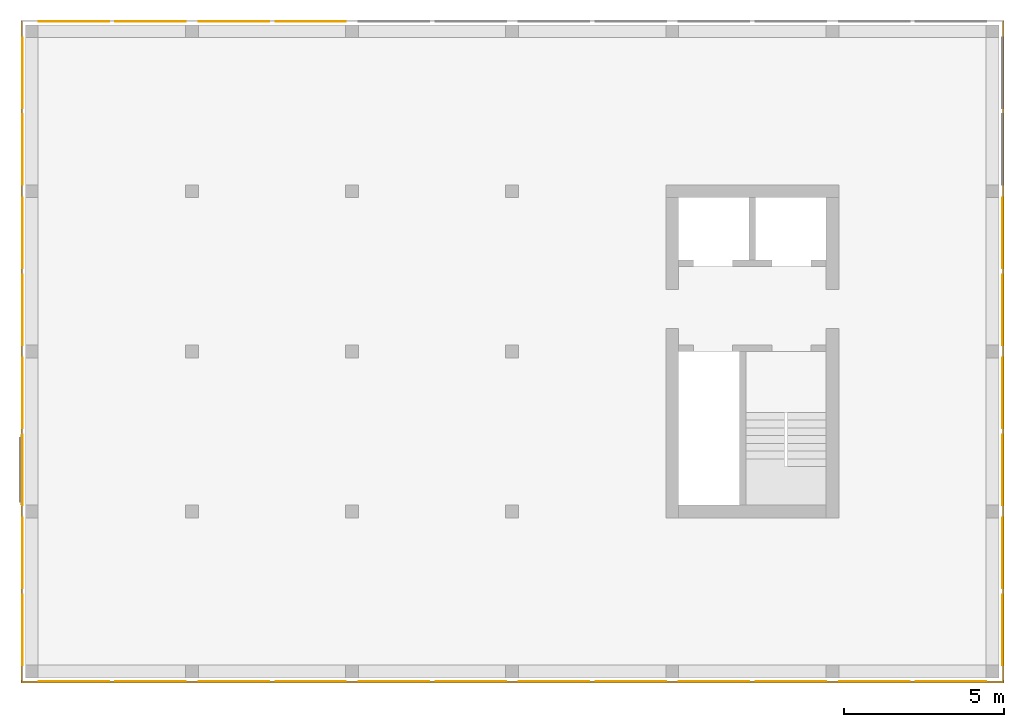
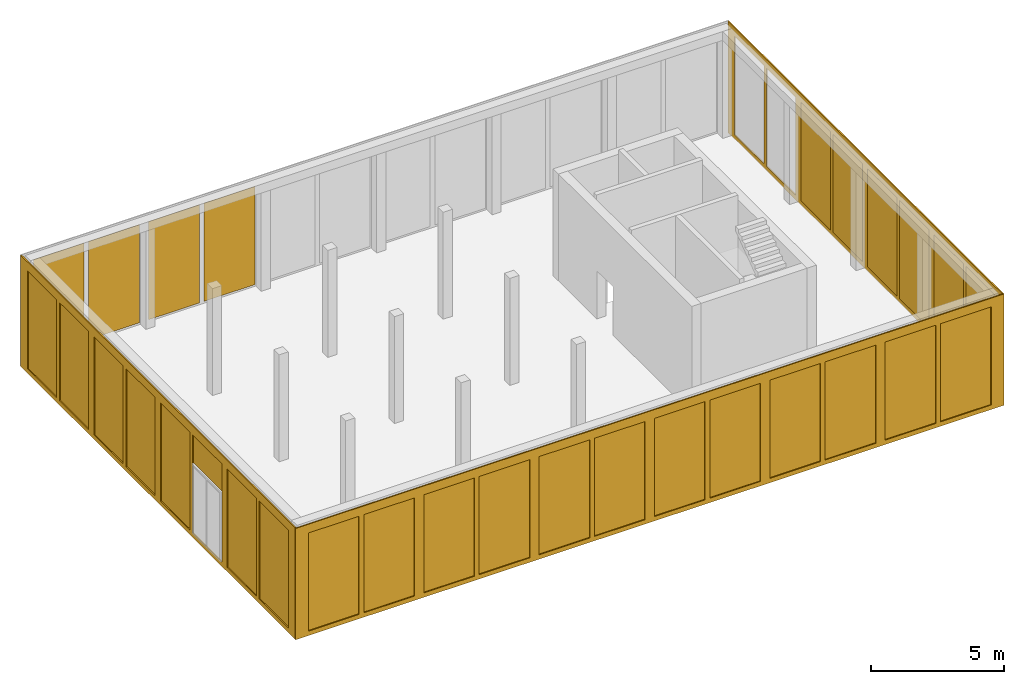
# One storey, part 3 of 5: 33 curtain walls.
"""IFC2X3 building model written with IfcOpenShell, lengths in metres."""

from ifc_helpers import new_model, entity, si_unit, converted_unit, frame, origin, place, context, subcontext, project, spatial, faceted_brep, material, element, save


model = new_model("IFC2X3")

# Units and contexts
model_context = context("Model", 3, precision=1e-05, world=origin())
body_context = subcontext(model_context, "Body", "Model", "MODEL_VIEW")
ifc_project = project(units=[si_unit("LENGTHUNIT", "METRE"), si_unit("AREAUNIT", "SQUARE_METRE"), si_unit("VOLUMEUNIT", "CUBIC_METRE"), si_unit("MASSUNIT", "GRAM", prefix="KILO"), converted_unit("PLANEANGLEUNIT", "DEGREE", entity("IfcPlaneAngleMeasure", 0.0174532925199433), si_unit("PLANEANGLEUNIT", "RADIAN"), dimensions=[0, 0, 0, 0, 0, 0, 0])], contexts=[model_context])

# Site, building, storey
site_placement = place(None, origin())
site = spatial("IfcSite", under=ifc_project, at=site_placement, CompositionType="ELEMENT")
building_placement = place(site_placement, origin())
building = spatial("IfcBuilding", under=site, at=building_placement, CompositionType="ELEMENT")
storey_placement = place(building_placement, frame((0.0, 0.0, -0.2)))
storey = spatial("IfcBuildingStorey", under=building, at=storey_placement, Name="Erdgeschoss", CompositionType="ELEMENT", Elevation=-0.2)

# Curtain walls
ifc_material_1 = material(Name="ALU")
curtain_wall_1_placement = place(storey_placement, frame((-0.139330706017223, -0.15, -0.2)))
element("IfcCurtainWall", 1, at=curtain_wall_1_placement, inside=storey, material=ifc_material_1, Name="Profil SN", context=body_context, shape_type="Brep", body=[
    faceted_brep([(0.0, 0.0500000000000001, 5.1), (30.7, 0.0500000000000001, 5.1), (30.7, 5.6843418860808e-17, 5.1), (0.0, 5.6843418860808e-17, 5.1), (30.7, 0.0500000000000001, 0.0), (30.7, 5.6843418860808e-17, 0.0), (30.15, 5.6843418860808e-17, 0.2), (30.15, 0.0500000000000001, 0.2), (30.15, 0.05, 4.7), (30.15, 0.0, 4.7), (27.95, 0.0500000000000001, 0.2), (27.95, 5.6843418860808e-17, 0.2), (27.95, 0.0, 4.7), (27.95, 0.05, 4.7), (27.75, 5.6843418860808e-17, 0.2), (27.75, 0.0500000000000001, 0.2), (27.75, 0.05, 4.7), (27.75, 0.0, 4.7), (25.55, 5.6843418860808e-17, 0.2), (25.55, 0.0500000000000001, 0.2), (25.55, 0.0, 4.7), (25.55, 0.05, 4.7), (25.15, 5.6843418860808e-17, 0.2), (25.15, 0.0500000000000001, 0.2), (25.15, 0.05, 4.7), (25.15, 0.0, 4.7), (22.95, 5.6843418860808e-17, 0.2), (22.95, 0.0500000000000001, 0.2), (22.95, 0.0, 4.7), (22.95, 0.05, 4.7), (22.75, 5.6843418860808e-17, 0.2), (22.75, 0.0500000000000001, 0.2), (22.75, 0.05, 4.7), (22.75, 0.0, 4.7), (20.55, 0.0500000000000001, 0.2), (20.55, 5.6843418860808e-17, 0.2), (20.55, 0.0, 4.7), (20.55, 0.05, 4.7), (20.15, 5.6843418860808e-17, 0.2), (20.15, 0.0500000000000001, 0.2), (20.15, 0.05, 4.7), (20.15, 0.0, 4.7), (17.95, 0.0500000000000001, 0.2), (17.95, 5.6843418860808e-17, 0.2), (17.75, 5.6843418860808e-17, 0.2), (15.55, 5.6843418860808e-17, 0.2), (15.55, 0.0500000000000001, 0.2), (17.75, 0.0500000000000001, 0.2), (12.95, 0.0500000000000001, 0.2), (15.15, 0.0500000000000001, 0.2), (15.15, 5.6843418860808e-17, 0.2), (12.95, 5.6843418860808e-17, 0.2), (12.75, 5.6843418860808e-17, 0.2), (10.55, 5.6843418860808e-17, 0.2), (10.55, 0.0500000000000001, 0.2), (12.75, 0.0500000000000001, 0.2), (7.95, 0.0500000000000001, 0.2), (10.15, 0.0500000000000001, 0.2), (10.15, 5.6843418860808e-17, 0.2), (7.95, 5.6843418860808e-17, 0.2), (7.75, 5.6843418860808e-17, 0.2), (5.55, 5.6843418860808e-17, 0.2), (5.55, 0.0500000000000001, 0.2), (7.75, 0.0500000000000001, 0.2), (0.0, 5.6843418860808e-17, 0.0), (0.0, 0.0500000000000001, 0.0), (0.550000000000004, 0.0500000000000001, 0.2), (0.550000000000007, 5.6843418860808e-17, 0.2), (0.550000000000004, 5.6843418860808e-17, 4.7), (0.550000000000007, 0.0500000000000001, 4.7), (10.15, 0.0500000000000001, 4.7), (10.15, 5.6843418860808e-17, 4.7), (10.55, 5.6843418860808e-17, 4.7), (10.55, 0.0500000000000001, 4.7), (5.15, 5.6843418860808e-17, 0.2), (5.15, 0.0500000000000001, 0.2), (5.15, 0.0500000000000001, 4.7), (5.15, 5.6843418860808e-17, 4.7), (5.55, 5.6843418860808e-17, 4.7), (5.55, 0.0500000000000001, 4.7), (7.75, 0.0500000000000001, 4.7), (7.75, 5.6843418860808e-17, 4.7), (7.95, 5.6843418860808e-17, 4.7), (7.95, 0.0500000000000001, 4.7), (15.15, 0.0500000000000001, 4.7), (15.15, 5.6843418860808e-17, 4.7), (15.55, 5.6843418860808e-17, 4.7), (15.55, 0.0500000000000001, 4.7), (17.75, 0.0500000000000001, 4.7), (17.75, 5.6843418860808e-17, 4.7), (17.95, 5.6843418860808e-17, 4.7), (17.95, 0.0500000000000001, 4.7), (12.75, 0.0500000000000001, 4.7), (12.75, 5.6843418860808e-17, 4.7), (12.95, 5.6843418860808e-17, 4.7), (12.95, 0.0500000000000001, 4.7), (2.75, 0.0, 0.2), (2.75, 0.05, 0.2), (2.95, 0.05, 0.2), (2.95, 0.0, 0.2), (2.95, 0.0, 4.7), (2.95, 0.05, 4.7), (2.75, 0.05, 4.7), (2.75, 0.0, 4.7)], [[[0, 1, 2, 3]], [[4, 5, 2, 1]], [[6, 7, 8, 9]], [[10, 7, 6, 11]], [[10, 11, 12, 13]], [[14, 15, 16, 17]], [[14, 18, 19, 15]], [[19, 18, 20, 21]], [[22, 23, 24, 25]], [[22, 26, 27, 23]], [[27, 26, 28, 29]], [[30, 31, 32, 33]], [[34, 31, 30, 35]], [[34, 35, 36, 37]], [[38, 39, 40, 41]], [[42, 39, 38, 43]], [[44, 45, 46, 47]], [[48, 49, 50, 51]], [[52, 53, 54, 55]], [[56, 57, 58, 59]], [[60, 61, 62, 63]], [[64, 65, 0, 3]], [[4, 65, 64, 5]], [[66, 67, 68, 69]], [[58, 57, 70, 71]], [[54, 53, 72, 73]], [[74, 75, 76, 77]], [[62, 61, 78, 79]], [[60, 63, 80, 81]], [[56, 59, 82, 83]], [[50, 49, 84, 85]], [[46, 45, 86, 87]], [[44, 47, 88, 89]], [[42, 43, 90, 91]], [[52, 55, 92, 93]], [[48, 51, 94, 95]], [[78, 81, 80, 79]], [[70, 83, 82, 71]], [[72, 93, 92, 73]], [[84, 95, 94, 85]], [[86, 89, 88, 87]], [[40, 91, 90, 41]], [[8, 13, 12, 9]], [[20, 17, 16, 21]], [[28, 25, 24, 29]], [[32, 37, 36, 33]], [[96, 67, 66, 97]], [[98, 75, 74, 99]], [[100, 77, 76, 101]], [[102, 69, 68, 103]], [[2, 5, 64, 3], [11, 6, 9, 12], [20, 18, 14, 17], [28, 26, 22, 25], [36, 35, 30, 33], [90, 43, 38, 41], [89, 86, 45, 44], [85, 94, 51, 50], [93, 72, 53, 52], [71, 82, 59, 58], [81, 78, 61, 60], [103, 68, 67, 96], [74, 77, 100, 99]], [[0, 65, 4, 1], [79, 80, 63, 62], [83, 70, 57, 56], [73, 92, 55, 54], [95, 84, 49, 48], [87, 88, 47, 46], [91, 40, 39, 42], [32, 31, 34, 37], [24, 23, 27, 29], [16, 15, 19, 21], [8, 7, 10, 13], [101, 76, 75, 98], [66, 69, 102, 97]], [[96, 97, 102, 103]], [[98, 99, 100, 101]]], orient=[[False], [False], [False], [False], [False], [False], [False], [False], [False], [False], [False], [False], [False], [False], [False], [False], [False], [False], [False], [False], [False], [False], [False], [False], [False], [False], [False], [False], [False], [False], [False], [False], [False], [False], [False], [False], [False], [False], [False], [False], [False], [False], [False], [False], [False], [False], [False], [False], [False], [False], [False, False, False, False, False, False, False, False, False, False, False, False, False], [False, False, False, False, False, False, False, False, False, False, False, False, False], [False], [False]]),
])
ifc_material_2 = material(Name="ALU")
curtain_wall_2_placement = place(storey_placement, frame((-0.139330706017222, -0.1, -0.2)))
element("IfcCurtainWall", 2, at=curtain_wall_2_placement, inside=storey, material=ifc_material_2, Name="Profil OW", context=body_context, shape_type="Brep", body=[
    faceted_brep([(0.0500000000000001, 20.6, 5.1), (0.0500000000000001, 0.0, 5.1), (8.5265128291212e-17, 0.0, 5.1), (5.6843418860808e-17, 20.6, 5.1), (0.0500000000000001, 0.0, 0.0), (8.5265128291212e-17, 0.0, 0.0), (5.6843418860808e-17, 20.6, 0.0), (0.0500000000000001, 20.6, 0.0), (0.0500000000000001, 5.1, 0.2), (5.6843418860808e-17, 5.1, 0.2), (5.6843418860808e-17, 5.1, 4.7), (0.0500000000000001, 5.1, 4.7), (8.5265128291212e-17, 0.499999999999996, 0.2), (0.0500000000000001, 0.499999999999995, 0.2), (0.0500000000000001, 0.499999999999996, 4.7), (8.5265128291212e-17, 0.499999999999995, 4.7), (5.6843418860808e-17, 7.69999999999999, 4.7), (5.6843418860808e-17, 5.5, 4.7), (0.0500000000000001, 5.5, 4.7), (0.0500000000000001, 7.7, 4.7), (0.0500000000000001, 7.69999999999999, 0.2), (5.6843418860808e-17, 7.7, 0.2), (0.0500000000000001, 5.5, 0.2), (5.6843418860808e-17, 5.5, 0.2), (5.6843418860808e-17, 10.5, 0.2), (0.0500000000000001, 10.5, 0.2), (0.0500000000000001, 10.5, 4.7), (5.6843418860808e-17, 10.5, 4.7), (5.6843418860808e-17, 12.7, 4.7), (0.0500000000000001, 12.7, 4.7), (0.0500000000000001, 12.7, 0.2), (5.6843418860808e-17, 12.7, 0.2), (5.6843418860808e-17, 12.9, 0.2), (0.0500000000000001, 12.9, 0.2), (0.0500000000000001, 12.9, 4.7), (5.6843418860808e-17, 12.9, 4.7), (5.6843418860808e-17, 15.1, 4.7), (0.0500000000000001, 15.1, 4.7), (0.0500000000000001, 15.1, 0.2), (5.6843418860808e-17, 15.1, 0.2), (5.6843418860808e-17, 15.5, 0.2), (0.0500000000000001, 15.5, 0.2), (0.0500000000000001, 15.5, 4.7), (5.6843418860808e-17, 15.5, 4.7), (5.6843418860808e-17, 17.7, 4.7), (0.0500000000000001, 17.7, 4.7), (0.0500000000000001, 17.7, 0.2), (5.6843418860808e-17, 17.7, 0.2), (5.6843418860808e-17, 17.9, 0.2), (0.0500000000000001, 17.9, 0.2), (0.0500000000000001, 17.9, 4.7), (5.6843418860808e-17, 17.9, 4.7), (5.6843418860808e-17, 20.1, 4.7), (0.0500000000000001, 20.1, 4.7), (0.0500000000000001, 20.1, 0.2), (5.6843418860808e-17, 20.1, 0.2), (0.0500000000000001, 7.9, 4.7), (0.0500000000000001, 10.1, 4.7), (5.6843418860808e-17, 10.1, 4.7), (5.6843418860808e-17, 7.9, 4.7), (0.0500000000000001, 10.1, 0.2), (5.6843418860808e-17, 10.1, 0.2), (5.6843418860808e-17, 7.9, 0.2), (0.0500000000000001, 7.9, 0.2), (0.0, 2.9, 0.2), (0.05, 2.9, 0.2), (0.0500000000000001, 2.7, 0.2), (2.8421709430404e-17, 2.7, 0.2), (2.8421709430404e-17, 2.7, 4.7), (0.0500000000000001, 2.7, 4.7), (0.05, 2.9, 4.7), (0.0, 2.9, 4.7)], [[[0, 1, 2, 3]], [[4, 5, 2, 1]], [[6, 7, 0, 3]], [[8, 9, 10, 11]], [[12, 13, 14, 15]], [[16, 17, 18, 19]], [[20, 21, 16, 19]], [[20, 22, 23, 21]], [[23, 22, 18, 17]], [[24, 25, 26, 27]], [[28, 27, 26, 29]], [[30, 31, 28, 29]], [[30, 25, 24, 31]], [[32, 33, 34, 35]], [[36, 35, 34, 37]], [[38, 39, 36, 37]], [[38, 33, 32, 39]], [[40, 41, 42, 43]], [[44, 43, 42, 45]], [[46, 47, 44, 45]], [[46, 41, 40, 47]], [[48, 49, 50, 51]], [[52, 51, 50, 53]], [[54, 55, 52, 53]], [[54, 49, 48, 55]], [[56, 57, 58, 59]], [[60, 61, 58, 57]], [[62, 61, 60, 63]], [[62, 63, 56, 59]], [[4, 7, 6, 5]], [[64, 9, 8, 65]], [[66, 13, 12, 67]], [[68, 15, 14, 69]], [[70, 11, 10, 71]], [[6, 3, 2, 5], [28, 31, 24, 27], [55, 48, 51, 52], [47, 40, 43, 44], [39, 32, 35, 36], [61, 62, 59, 58], [21, 23, 17, 16], [71, 10, 9, 64], [12, 15, 68, 67]], [[7, 4, 1, 0], [56, 63, 60, 57], [49, 54, 53, 50], [41, 46, 45, 42], [33, 38, 37, 34], [25, 30, 29, 26], [18, 22, 20, 19], [69, 14, 13, 66], [8, 11, 70, 65]], [[64, 65, 70, 71]], [[66, 67, 68, 69]]], orient=[[False], [False], [False], [False], [False], [False], [False], [False], [False], [False], [False], [False], [False], [False], [False], [False], [False], [False], [False], [False], [False], [False], [False], [False], [False], [False], [False], [False], [False], [False], [False], [False], [False], [False], [False, False, False, False, False, False, False, False, False], [False, False, False, False, False, False, False, False, False], [False], [False]]),
])
ifc_material_3 = material(Name="ALU")
curtain_wall_3_placement = place(storey_placement, frame((30.5106692939828, -0.1, -0.2)))
element("IfcCurtainWall", 3, at=curtain_wall_3_placement, inside=storey, material=ifc_material_3, Name="Profil OW", context=body_context, shape_type="Brep", body=[
    faceted_brep([(0.05, 20.6, 5.1), (0.05, 0.0, 5.1), (0.0, 0.0, 5.1), (0.0, 20.6, 5.1), (0.05, 0.0, 0.0), (0.05, 20.6, 0.0), (0.0, 20.6, 0.0), (0.0, 0.0, 0.0), (3.63797880709171e-15, 0.499999999999996, 0.2), (0.0500000000000036, 0.499999999999996, 0.2), (0.0500000000000036, 0.499999999999996, 4.7), (3.63797880709171e-15, 0.499999999999996, 4.7), (0.05, 2.70000000000001, 0.2), (0.0, 2.70000000000001, 0.2), (0.0, 2.70000000000001, 4.7), (0.05, 2.70000000000001, 4.7), (0.05, 2.90000000000001, 0.2), (0.05, 2.90000000000001, 4.7), (0.0, 2.90000000000001, 4.7), (0.0, 2.90000000000001, 0.2), (0.0, 7.7, 0.2), (0.0, 7.7, 4.7), (0.05, 7.7, 4.7), (0.05, 7.7, 0.2), (0.05, 7.9, 0.2), (0.05, 7.9, 4.7), (0.0, 7.9, 4.7), (0.0, 7.9, 0.2), (0.0, 12.7, 0.2), (0.0, 12.7, 4.7), (0.05, 12.7, 4.7), (0.05, 12.7, 0.2), (0.05, 12.9, 0.2), (0.05, 12.9, 4.7), (0.0, 12.9, 4.7), (0.0, 12.9, 0.2), (0.0, 5.5, 0.2), (0.05, 5.5, 0.2), (0.05, 5.1, 0.2), (0.0, 5.1, 0.2), (0.0, 5.1, 4.7), (0.05, 5.1, 4.7), (0.05, 5.5, 4.7), (0.0, 5.5, 4.7), (0.0, 10.5, 0.2), (0.05, 10.5, 0.2), (0.05, 10.1, 0.2), (0.0, 10.1, 0.2), (0.0, 10.1, 4.7), (0.05, 10.1, 4.7), (0.05, 10.5, 4.7), (0.0, 10.5, 4.7), (0.05, 15.1, 0.2), (0.0, 15.1, 0.2), (0.0, 15.1, 4.7), (0.05, 15.1, 4.7), (0.0, 15.5, 0.2), (0.05, 15.5, 0.2), (0.05, 15.5, 4.7), (0.0, 15.5, 4.7), (0.05, 20.1, 0.2), (0.0, 20.1, 0.2), (0.0, 20.1, 4.7), (0.05, 20.1, 4.7), (0.05, 17.7, 0.2), (0.0, 17.7, 0.2), (0.0, 17.9, 0.2), (0.05, 17.9, 0.2), (0.05, 17.9, 4.7), (0.0, 17.9, 4.7), (0.0, 17.7, 4.7), (0.05, 17.7, 4.7)], [[[0, 1, 2, 3]], [[4, 5, 6, 7]], [[8, 9, 10, 11]], [[12, 9, 8, 13]], [[14, 11, 10, 15]], [[13, 14, 15, 12]], [[16, 17, 18, 19]], [[20, 21, 22, 23]], [[24, 25, 26, 27]], [[28, 29, 30, 31]], [[32, 33, 34, 35]], [[36, 20, 23, 37]], [[38, 16, 19, 39]], [[40, 18, 17, 41]], [[42, 22, 21, 43]], [[36, 37, 42, 43]], [[38, 39, 40, 41]], [[44, 28, 31, 45]], [[46, 24, 27, 47]], [[48, 26, 25, 49]], [[50, 30, 29, 51]], [[44, 45, 50, 51]], [[46, 47, 48, 49]], [[52, 32, 35, 53]], [[54, 34, 33, 55]], [[56, 57, 58, 59]], [[52, 53, 54, 55]], [[60, 61, 62, 63]], [[64, 57, 56, 65]], [[66, 61, 60, 67]], [[68, 63, 62, 69]], [[70, 59, 58, 71]], [[65, 70, 71, 64]], [[67, 68, 69, 66]], [[4, 7, 2, 1]], [[6, 5, 0, 3]], [[2, 7, 6, 3], [13, 8, 11, 14], [39, 19, 18, 40], [21, 20, 36, 43], [47, 27, 26, 48], [29, 28, 44, 51], [53, 35, 34, 54], [65, 56, 59, 70], [62, 61, 66, 69]], [[5, 4, 1, 0], [10, 9, 12, 15], [37, 23, 22, 42], [17, 16, 38, 41], [45, 31, 30, 50], [25, 24, 46, 49], [33, 32, 52, 55], [67, 60, 63, 68], [58, 57, 64, 71]]], orient=[[False], [False], [False], [False], [False], [False], [False], [False], [False], [False], [False], [False], [False], [False], [False], [False], [False], [False], [False], [False], [False], [False], [False], [False], [False], [False], [False], [False], [False], [False], [False], [False], [False], [False], [False], [False], [False, False, False, False, False, False, False, False, False], [False, False, False, False, False, False, False, False, False]]),
])
ifc_material_4 = material(Name="VSG")
curtain_wall_4_placement = place(storey_placement, frame((-0.0943307060172217, 0.399999999999993, 0.0)))
element("IfcCurtainWall", 4, at=curtain_wall_4_placement, inside=storey, material=ifc_material_4, context=body_context, shape_type="Brep", body=[
    faceted_brep([(0.005, 0.0, 0.0), (0.0, 0.0, 0.0), (0.0, 0.0, 4.5), (0.005, 0.0, 4.5), (0.0, 2.2, 0.0), (0.0, 2.2, 4.5), (0.005, 2.2, 0.0), (0.005, 2.2, 4.5)], [[[0, 1, 2, 3]], [[1, 4, 5, 2]], [[4, 6, 7, 5]], [[6, 0, 3, 7]], [[7, 3, 2, 5]], [[0, 6, 4, 1]]], orient=[[False], [False], [False], [False], [False], [False]]),
])
ifc_material_5 = material(Name="VSG")
curtain_wall_5_placement = place(storey_placement, frame((-0.0943307060172217, 15.4, 0.0)))
element("IfcCurtainWall", 5, at=curtain_wall_5_placement, inside=storey, material=ifc_material_5, context=body_context, shape_type="Brep", body=[
    faceted_brep([(0.005, 1.81898940354586e-15, 0.0), (0.0, 1.81898940354586e-15, 0.0), (0.0, 1.81898940354586e-15, 4.5), (0.005, 1.81898940354586e-15, 4.5), (0.0, 2.20000000000001, 0.0), (0.0, 2.20000000000001, 4.5), (0.005, 2.20000000000001, 0.0), (0.005, 2.20000000000001, 4.5)], [[[0, 1, 2, 3]], [[1, 4, 5, 2]], [[4, 6, 7, 5]], [[6, 0, 3, 7]], [[7, 3, 2, 5]], [[0, 6, 4, 1]]], orient=[[False], [False], [False], [False], [False], [False]]),
])
ifc_material_6 = material(Name="VSG")
curtain_wall_6_placement = place(storey_placement, frame((-0.0943307060172217, 17.8, 0.0)))
element("IfcCurtainWall", 6, at=curtain_wall_6_placement, inside=storey, material=ifc_material_6, context=body_context, shape_type="Brep", body=[
    faceted_brep([(0.005, 0.0, 0.0), (0.0, 0.0, 0.0), (0.0, 0.0, 4.5), (0.005, 0.0, 4.5), (0.0, 2.2, 0.0), (0.0, 2.2, 4.5), (0.005, 2.2, 0.0), (0.005, 2.2, 4.5)], [[[0, 1, 2, 3]], [[1, 4, 5, 2]], [[4, 6, 7, 5]], [[6, 0, 3, 7]], [[7, 3, 2, 5]], [[0, 6, 4, 1]]], orient=[[False], [False], [False], [False], [False], [False]]),
])
ifc_material_7 = material(Name="VSG")
curtain_wall_7_placement = place(storey_placement, frame((-0.0943307060172217, 12.8, 0.0)))
element("IfcCurtainWall", 7, at=curtain_wall_7_placement, inside=storey, material=ifc_material_7, context=body_context, shape_type="Brep", body=[
    faceted_brep([(0.005, 0.0, 0.0), (0.0, 0.0, 0.0), (0.0, 0.0, 4.5), (0.005, 0.0, 4.5), (0.0, 2.2, 0.0), (0.0, 2.2, 4.5), (0.005, 2.2, 0.0), (0.005, 2.2, 4.5)], [[[0, 1, 2, 3]], [[1, 4, 5, 2]], [[4, 6, 7, 5]], [[6, 0, 3, 7]], [[7, 3, 2, 5]], [[0, 6, 4, 1]]], orient=[[False], [False], [False], [False], [False], [False]]),
])
ifc_material_8 = material(Name="VSG")
curtain_wall_8_placement = place(storey_placement, frame((-0.0943307060172217, 10.4, 0.0)))
element("IfcCurtainWall", 8, at=curtain_wall_8_placement, inside=storey, material=ifc_material_8, context=body_context, shape_type="Brep", body=[
    faceted_brep([(0.005, 0.0, 0.0), (0.0, 0.0, 0.0), (0.0, 0.0, 4.5), (0.005, 0.0, 4.5), (0.0, 2.2, 0.0), (0.0, 2.2, 4.5), (0.005, 2.2, 0.0), (0.005, 2.2, 4.5)], [[[0, 1, 2, 3]], [[1, 4, 5, 2]], [[4, 6, 7, 5]], [[6, 0, 3, 7]], [[7, 3, 2, 5]], [[0, 6, 4, 1]]], orient=[[False], [False], [False], [False], [False], [False]]),
])
ifc_material_9 = material(Name="VSG")
curtain_wall_9_placement = place(storey_placement, frame((-0.0943307060172217, 7.8, 0.0)))
element("IfcCurtainWall", 9, at=curtain_wall_9_placement, inside=storey, material=ifc_material_9, context=body_context, shape_type="Brep", body=[
    faceted_brep([(0.005, 0.0, 0.0), (0.0, 0.0, 0.0), (0.0, 0.0, 4.5), (0.005, 0.0, 4.5), (0.0, 2.2, 0.0), (0.0, 2.2, 4.5), (0.005, 2.2, 0.0), (0.005, 2.2, 4.5)], [[[0, 1, 2, 3]], [[1, 4, 5, 2]], [[4, 6, 7, 5]], [[6, 0, 3, 7]], [[7, 3, 2, 5]], [[0, 6, 4, 1]]], orient=[[False], [False], [False], [False], [False], [False]]),
])
ifc_material_10 = material(Name="VSG")
curtain_wall_10_placement = place(storey_placement, frame((0.410669293982781, -0.105, 0.0)))
element("IfcCurtainWall", 10, at=curtain_wall_10_placement, inside=storey, material=ifc_material_10, context=body_context, shape_type="Brep", body=[
    faceted_brep([(2.2, 0.00500000000000001, 0.0), (2.2, 1.4210854715202e-17, 0.0), (2.2, 1.4210854715202e-17, 4.5), (2.2, 0.00500000000000001, 4.5), (0.0, 2.8421709430404e-16, 0.0), (0.0, 2.8421709430404e-16, 4.5), (0.0, 0.00500000000000028, 0.0), (0.0, 0.00500000000000028, 4.5)], [[[0, 1, 2, 3]], [[1, 4, 5, 2]], [[4, 6, 7, 5]], [[6, 0, 3, 7]], [[7, 3, 2, 5]], [[0, 6, 4, 1]]], orient=[[False], [False], [False], [False], [False], [False]]),
])
ifc_material_11 = material(Name="VSG")
curtain_wall_11_placement = place(storey_placement, frame((7.81066929398278, -0.105, 0.0)))
element("IfcCurtainWall", 11, at=curtain_wall_11_placement, inside=storey, material=ifc_material_11, context=body_context, shape_type="Brep", body=[
    faceted_brep([(2.2, 0.00500000000000001, 0.0), (2.2, 1.4210854715202e-17, 0.0), (2.2, 1.4210854715202e-17, 4.5), (2.2, 0.00500000000000001, 4.5), (0.0, 2.8421709430404e-16, 0.0), (0.0, 2.8421709430404e-16, 4.5), (0.0, 0.00500000000000028, 0.0), (0.0, 0.00500000000000028, 4.5)], [[[0, 1, 2, 3]], [[1, 4, 5, 2]], [[4, 6, 7, 5]], [[6, 0, 3, 7]], [[7, 3, 2, 5]], [[0, 6, 4, 1]]], orient=[[False], [False], [False], [False], [False], [False]]),
])
ifc_material_12 = material(Name="VSG")
curtain_wall_12_placement = place(storey_placement, frame((10.4106692939828, -0.105, 0.0)))
element("IfcCurtainWall", 12, at=curtain_wall_12_placement, inside=storey, material=ifc_material_12, context=body_context, shape_type="Brep", body=[
    faceted_brep([(2.2, 0.00500000000000001, 0.0), (2.2, 1.4210854715202e-17, 0.0), (2.2, 1.4210854715202e-17, 4.5), (2.2, 0.00500000000000001, 4.5), (0.0, 2.8421709430404e-16, 0.0), (0.0, 2.8421709430404e-16, 4.5), (0.0, 0.00500000000000028, 0.0), (0.0, 0.00500000000000028, 4.5)], [[[0, 1, 2, 3]], [[1, 4, 5, 2]], [[4, 6, 7, 5]], [[6, 0, 3, 7]], [[7, 3, 2, 5]], [[0, 6, 4, 1]]], orient=[[False], [False], [False], [False], [False], [False]]),
])
ifc_material_13 = material(Name="VSG")
curtain_wall_13_placement = place(storey_placement, frame((12.8106692939828, -0.105, 0.0)))
element("IfcCurtainWall", 13, at=curtain_wall_13_placement, inside=storey, material=ifc_material_13, context=body_context, shape_type="Brep", body=[
    faceted_brep([(2.2, 0.00500000000000001, 0.0), (2.2, 1.4210854715202e-17, 0.0), (2.2, 1.4210854715202e-17, 4.5), (2.2, 0.00500000000000001, 4.5), (0.0, 2.8421709430404e-16, 0.0), (0.0, 2.8421709430404e-16, 4.5), (0.0, 0.00500000000000028, 0.0), (0.0, 0.00500000000000028, 4.5)], [[[0, 1, 2, 3]], [[1, 4, 5, 2]], [[4, 6, 7, 5]], [[6, 0, 3, 7]], [[7, 3, 2, 5]], [[0, 6, 4, 1]]], orient=[[False], [False], [False], [False], [False], [False]]),
])
ifc_material_14 = material(Name="VSG")
curtain_wall_14_placement = place(storey_placement, frame((15.4106692939828, -0.105, 0.0)))
element("IfcCurtainWall", 14, at=curtain_wall_14_placement, inside=storey, material=ifc_material_14, context=body_context, shape_type="Brep", body=[
    faceted_brep([(2.2, 0.00500000000000001, 0.0), (2.2, 1.4210854715202e-17, 0.0), (2.2, 1.4210854715202e-17, 4.5), (2.2, 0.00500000000000001, 4.5), (-1.81898940354586e-15, 2.8421709430404e-16, 0.0), (-1.81898940354586e-15, 2.8421709430404e-16, 4.5), (-1.81898940354586e-15, 0.00500000000000028, 0.0), (-1.81898940354586e-15, 0.00500000000000028, 4.5)], [[[0, 1, 2, 3]], [[1, 4, 5, 2]], [[4, 6, 7, 5]], [[6, 0, 3, 7]], [[7, 3, 2, 5]], [[0, 6, 4, 1]]], orient=[[False], [False], [False], [False], [False], [False]]),
])
ifc_material_15 = material(Name="VSG")
curtain_wall_15_placement = place(storey_placement, frame((17.8106692939828, -0.105, 0.0)))
element("IfcCurtainWall", 15, at=curtain_wall_15_placement, inside=storey, material=ifc_material_15, context=body_context, shape_type="Brep", body=[
    faceted_brep([(2.2, 0.00500000000000001, 0.0), (2.2, 1.4210854715202e-17, 0.0), (2.2, 1.4210854715202e-17, 4.5), (2.2, 0.00500000000000001, 4.5), (-3.63797880709171e-15, 2.8421709430404e-16, 0.0), (-3.63797880709171e-15, 2.8421709430404e-16, 4.5), (-3.63797880709171e-15, 0.00500000000000028, 0.0), (-3.63797880709171e-15, 0.00500000000000028, 4.5)], [[[0, 1, 2, 3]], [[1, 4, 5, 2]], [[4, 6, 7, 5]], [[6, 0, 3, 7]], [[7, 3, 2, 5]], [[0, 6, 4, 1]]], orient=[[False], [False], [False], [False], [False], [False]]),
])
ifc_material_16 = material(Name="VSG")
curtain_wall_16_placement = place(storey_placement, frame((22.8106692939828, -0.105, 0.0)))
element("IfcCurtainWall", 16, at=curtain_wall_16_placement, inside=storey, material=ifc_material_16, context=body_context, shape_type="Brep", body=[
    faceted_brep([(2.2, 0.00500000000000001, 0.0), (2.2, 1.4210854715202e-17, 0.0), (2.2, 1.4210854715202e-17, 4.5), (2.2, 0.00500000000000001, 4.5), (-3.63797880709171e-15, 2.8421709430404e-16, 0.0), (-3.63797880709171e-15, 2.8421709430404e-16, 4.5), (-3.63797880709171e-15, 0.00500000000000028, 0.0), (-3.63797880709171e-15, 0.00500000000000028, 4.5)], [[[0, 1, 2, 3]], [[1, 4, 5, 2]], [[4, 6, 7, 5]], [[6, 0, 3, 7]], [[7, 3, 2, 5]], [[0, 6, 4, 1]]], orient=[[False], [False], [False], [False], [False], [False]]),
])
ifc_material_17 = material(Name="VSG")
curtain_wall_17_placement = place(storey_placement, frame((25.4106692939828, -0.105, 0.0)))
element("IfcCurtainWall", 17, at=curtain_wall_17_placement, inside=storey, material=ifc_material_17, context=body_context, shape_type="Brep", body=[
    faceted_brep([(2.2, 0.00500000000000001, 0.0), (2.2, 1.4210854715202e-17, 0.0), (2.2, 1.4210854715202e-17, 4.5), (2.2, 0.00500000000000001, 4.5), (-3.63797880709171e-15, 2.8421709430404e-16, 0.0), (-3.63797880709171e-15, 2.8421709430404e-16, 4.5), (-3.63797880709171e-15, 0.00500000000000028, 0.0), (-3.63797880709171e-15, 0.00500000000000028, 4.5)], [[[0, 1, 2, 3]], [[1, 4, 5, 2]], [[4, 6, 7, 5]], [[6, 0, 3, 7]], [[7, 3, 2, 5]], [[0, 6, 4, 1]]], orient=[[False], [False], [False], [False], [False], [False]]),
])
ifc_material_18 = material(Name="VSG")
curtain_wall_18_placement = place(storey_placement, frame((27.8106692939828, -0.105, 0.0)))
element("IfcCurtainWall", 18, at=curtain_wall_18_placement, inside=storey, material=ifc_material_18, context=body_context, shape_type="Brep", body=[
    faceted_brep([(2.2, 0.00500000000000001, 0.0), (2.2, 1.4210854715202e-17, 0.0), (2.2, 1.4210854715202e-17, 4.5), (2.2, 0.00500000000000001, 4.5), (-3.63797880709171e-15, 2.8421709430404e-16, 0.0), (-3.63797880709171e-15, 2.8421709430404e-16, 4.5), (-3.63797880709171e-15, 0.00500000000000028, 0.0), (-3.63797880709171e-15, 0.00500000000000028, 4.5)], [[[0, 1, 2, 3]], [[1, 4, 5, 2]], [[4, 6, 7, 5]], [[6, 0, 3, 7]], [[7, 3, 2, 5]], [[0, 6, 4, 1]]], orient=[[False], [False], [False], [False], [False], [False]]),
])
ifc_material_19 = material(Name="VSG")
curtain_wall_19_placement = place(storey_placement, frame((30.5106692939828, 12.8, 0.0)))
element("IfcCurtainWall", 19, at=curtain_wall_19_placement, inside=storey, material=ifc_material_19, context=body_context, shape_type="Brep", body=[
    faceted_brep([(0.0, 0.0, 0.0), (0.0, 0.0, 4.5), (0.005, 0.0, 4.5), (0.005, 0.0, 0.0), (0.005, 2.2, 4.5), (0.005, 2.2, 0.0), (0.0, 2.2, 4.5), (0.0, 2.2, 0.0)], [[[0, 1, 2, 3]], [[3, 2, 4, 5]], [[5, 4, 6, 7]], [[7, 6, 1, 0]], [[6, 4, 2, 1]], [[0, 3, 5, 7]]], orient=[[False], [False], [False], [False], [False], [False]]),
])
ifc_material_20 = material(Name="VSG")
curtain_wall_20_placement = place(storey_placement, frame((30.5106692939828, 10.4, 0.0)))
element("IfcCurtainWall", 20, at=curtain_wall_20_placement, inside=storey, material=ifc_material_20, context=body_context, shape_type="Brep", body=[
    faceted_brep([(0.0, 0.0, 0.0), (0.0, 0.0, 4.5), (0.005, 0.0, 4.5), (0.005, 0.0, 0.0), (0.005, 2.2, 4.5), (0.005, 2.2, 0.0), (0.0, 2.2, 4.5), (0.0, 2.2, 0.0)], [[[0, 1, 2, 3]], [[3, 2, 4, 5]], [[5, 4, 6, 7]], [[7, 6, 1, 0]], [[6, 4, 2, 1]], [[0, 3, 5, 7]]], orient=[[False], [False], [False], [False], [False], [False]]),
])
ifc_material_21 = material(Name="VSG")
curtain_wall_21_placement = place(storey_placement, frame((30.5106692939828, 7.8, 0.0)))
element("IfcCurtainWall", 21, at=curtain_wall_21_placement, inside=storey, material=ifc_material_21, context=body_context, shape_type="Brep", body=[
    faceted_brep([(0.0, 0.0, 0.0), (0.0, 0.0, 4.5), (0.005, 0.0, 4.5), (0.005, 0.0, 0.0), (0.005, 2.2, 4.5), (0.005, 2.2, 0.0), (0.0, 2.2, 4.5), (0.0, 2.2, 0.0)], [[[0, 1, 2, 3]], [[3, 2, 4, 5]], [[5, 4, 6, 7]], [[7, 6, 1, 0]], [[6, 4, 2, 1]], [[0, 3, 5, 7]]], orient=[[False], [False], [False], [False], [False], [False]]),
])
ifc_material_22 = material(Name="VSG")
curtain_wall_22_placement = place(storey_placement, frame((30.5106692939828, 5.39999999999999, 0.0)))
element("IfcCurtainWall", 22, at=curtain_wall_22_placement, inside=storey, material=ifc_material_22, context=body_context, shape_type="Brep", body=[
    faceted_brep([(0.0, 0.0, 0.0), (0.0, 0.0, 4.5), (0.005, 0.0, 4.5), (0.005, 0.0, 0.0), (0.005, 2.2, 4.5), (0.005, 2.2, 0.0), (0.0, 2.2, 4.5), (0.0, 2.2, 0.0)], [[[0, 1, 2, 3]], [[3, 2, 4, 5]], [[5, 4, 6, 7]], [[7, 6, 1, 0]], [[6, 4, 2, 1]], [[0, 3, 5, 7]]], orient=[[False], [False], [False], [False], [False], [False]]),
])
ifc_material_23 = material(Name="VSG")
curtain_wall_23_placement = place(storey_placement, frame((30.5106692939828, 2.79999999999999, 0.0)))
element("IfcCurtainWall", 23, at=curtain_wall_23_placement, inside=storey, material=ifc_material_23, context=body_context, shape_type="Brep", body=[
    faceted_brep([(0.0, 0.0, 0.0), (0.0, 0.0, 4.5), (0.005, 0.0, 4.5), (0.005, 0.0, 0.0), (0.005, 2.2, 4.5), (0.005, 2.2, 0.0), (0.0, 2.2, 4.5), (0.0, 2.2, 0.0)], [[[0, 1, 2, 3]], [[3, 2, 4, 5]], [[5, 4, 6, 7]], [[7, 6, 1, 0]], [[6, 4, 2, 1]], [[0, 3, 5, 7]]], orient=[[False], [False], [False], [False], [False], [False]]),
])
ifc_material_24 = material(Name="VSG")
curtain_wall_24_placement = place(storey_placement, frame((30.5106692939828, 0.399999999999993, 0.0)))
element("IfcCurtainWall", 24, at=curtain_wall_24_placement, inside=storey, material=ifc_material_24, context=body_context, shape_type="Brep", body=[
    faceted_brep([(0.0, 0.0, 0.0), (0.0, 0.0, 4.5), (0.005, 0.0, 4.5), (0.005, 0.0, 0.0), (0.005, 2.2, 4.5), (0.005, 2.2, 0.0), (0.0, 2.2, 4.5), (0.0, 2.2, 0.0)], [[[0, 1, 2, 3]], [[3, 2, 4, 5]], [[5, 4, 6, 7]], [[7, 6, 1, 0]], [[6, 4, 2, 1]], [[0, 3, 5, 7]]], orient=[[False], [False], [False], [False], [False], [False]]),
])
ifc_material_25 = material(Name="VSG")
curtain_wall_25_placement = place(storey_placement, frame((2.81066929398278, 20.5, 0.0)))
element("IfcCurtainWall", 25, at=curtain_wall_25_placement, inside=storey, material=ifc_material_25, context=body_context, shape_type="Brep", body=[
    faceted_brep([(2.2, 0.0, 0.0), (2.2, 0.0, 4.5), (2.2, 0.005, 4.5), (2.2, 0.005, 0.0), (0.0, 0.005, 4.5), (0.0, 0.005, 0.0), (0.0, 0.0, 4.5), (0.0, 0.0, 0.0)], [[[0, 1, 2, 3]], [[3, 2, 4, 5]], [[5, 4, 6, 7]], [[7, 6, 1, 0]], [[6, 4, 2, 1]], [[0, 3, 5, 7]]], orient=[[False], [False], [False], [False], [False], [False]]),
])
ifc_material_26 = material(Name="VSG")
curtain_wall_26_placement = place(storey_placement, frame((5.41066929398278, 20.5, 0.0)))
element("IfcCurtainWall", 26, at=curtain_wall_26_placement, inside=storey, material=ifc_material_26, context=body_context, shape_type="Brep", body=[
    faceted_brep([(2.2, 0.0, 0.0), (2.2, 0.0, 4.5), (2.2, 0.005, 4.5), (2.2, 0.005, 0.0), (0.0, 0.005, 4.5), (0.0, 0.005, 0.0), (0.0, 0.0, 4.5), (0.0, 0.0, 0.0)], [[[0, 1, 2, 3]], [[3, 2, 4, 5]], [[5, 4, 6, 7]], [[7, 6, 1, 0]], [[6, 4, 2, 1]], [[0, 3, 5, 7]]], orient=[[False], [False], [False], [False], [False], [False]]),
])
ifc_material_27 = material(Name="VSG")
curtain_wall_27_placement = place(storey_placement, frame((7.81066929398278, 20.5, 0.0)))
element("IfcCurtainWall", 27, at=curtain_wall_27_placement, inside=storey, material=ifc_material_27, context=body_context, shape_type="Brep", body=[
    faceted_brep([(2.2, 0.0, 0.0), (2.2, 0.0, 4.5), (2.2, 0.005, 4.5), (2.2, 0.005, 0.0), (0.0, 0.005, 4.5), (0.0, 0.005, 0.0), (0.0, 0.0, 4.5), (0.0, 0.0, 0.0)], [[[0, 1, 2, 3]], [[3, 2, 4, 5]], [[5, 4, 6, 7]], [[7, 6, 1, 0]], [[6, 4, 2, 1]], [[0, 3, 5, 7]]], orient=[[False], [False], [False], [False], [False], [False]]),
])
ifc_material_28 = material(Name="VSG")
curtain_wall_28_placement = place(storey_placement, frame((20.4106692939828, -0.105, 0.0)))
element("IfcCurtainWall", 28, at=curtain_wall_28_placement, inside=storey, material=ifc_material_28, context=body_context, shape_type="Brep", body=[
    faceted_brep([(2.2, 0.00500000000000001, 0.0), (2.2, 1.4210854715202e-17, 0.0), (2.2, 1.4210854715202e-17, 4.5), (2.2, 0.00500000000000001, 4.5), (-3.63797880709171e-15, 2.8421709430404e-16, 0.0), (-3.63797880709171e-15, 2.8421709430404e-16, 4.5), (-3.63797880709171e-15, 0.00500000000000028, 0.0), (-3.63797880709171e-15, 0.00500000000000028, 4.5)], [[[0, 1, 2, 3]], [[1, 4, 5, 2]], [[4, 6, 7, 5]], [[6, 0, 3, 7]], [[7, 3, 2, 5]], [[0, 6, 4, 1]]], orient=[[False], [False], [False], [False], [False], [False]]),
])
ifc_material_29 = material(Name="VSG")
curtain_wall_29_placement = place(storey_placement, frame((0.410669293982781, 20.5, 0.0)))
element("IfcCurtainWall", 29, at=curtain_wall_29_placement, inside=storey, material=ifc_material_29, context=body_context, shape_type="Brep", body=[
    faceted_brep([(2.2, 0.0, 0.0), (2.2, 0.0, 4.5), (2.2, 0.005, 4.5), (2.2, 0.005, 0.0), (0.0, 0.005, 4.5), (0.0, 0.005, 0.0), (0.0, 0.0, 4.5), (0.0, 0.0, 0.0)], [[[0, 1, 2, 3]], [[3, 2, 4, 5]], [[5, 4, 6, 7]], [[7, 6, 1, 0]], [[6, 4, 2, 1]], [[0, 3, 5, 7]]], orient=[[False], [False], [False], [False], [False], [False]]),
])
ifc_material_30 = material(Name="VSG")
curtain_wall_30_placement = place(storey_placement, frame((5.41066929398278, -0.105, 0.0)))
element("IfcCurtainWall", 30, at=curtain_wall_30_placement, inside=storey, material=ifc_material_30, context=body_context, shape_type="Brep", body=[
    faceted_brep([(2.2, 0.00500000000000001, 0.0), (2.2, 1.4210854715202e-17, 0.0), (2.2, 1.4210854715202e-17, 4.5), (2.2, 0.00500000000000001, 4.5), (0.0, 2.8421709430404e-16, 0.0), (0.0, 2.8421709430404e-16, 4.5), (0.0, 0.00500000000000028, 0.0), (0.0, 0.00500000000000028, 4.5)], [[[0, 1, 2, 3]], [[1, 4, 5, 2]], [[4, 6, 7, 5]], [[6, 0, 3, 7]], [[7, 3, 2, 5]], [[0, 6, 4, 1]]], orient=[[False], [False], [False], [False], [False], [False]]),
])
ifc_material_31 = material(Name="VSG")
curtain_wall_31_placement = place(storey_placement, frame((2.81066929398278, -0.105, 0.0)))
element("IfcCurtainWall", 31, at=curtain_wall_31_placement, inside=storey, material=ifc_material_31, context=body_context, shape_type="Brep", body=[
    faceted_brep([(2.2, 0.00500000000000001, 0.0), (2.2, 1.4210854715202e-17, 0.0), (2.2, 1.4210854715202e-17, 4.5), (2.2, 0.00500000000000001, 4.5), (0.0, 2.8421709430404e-16, 0.0), (0.0, 2.8421709430404e-16, 4.5), (0.0, 0.00500000000000028, 0.0), (0.0, 0.00500000000000028, 4.5)], [[[0, 1, 2, 3]], [[1, 4, 5, 2]], [[4, 6, 7, 5]], [[6, 0, 3, 7]], [[7, 3, 2, 5]], [[0, 6, 4, 1]]], orient=[[False], [False], [False], [False], [False], [False]]),
])
ifc_material_32 = material(Name="VSG")
curtain_wall_32_placement = place(storey_placement, frame((-0.0943307060172222, 5.39999999999999, 3.195)))
element("IfcCurtainWall", 32, at=curtain_wall_32_placement, inside=storey, material=ifc_material_32, context=body_context, shape_type="Brep", body=[
    faceted_brep([(0.00500000000000001, 1.81898940354586e-15, 0.0), (1.4210854715202e-17, 1.81898940354586e-15, 0.0), (5.11590769747272e-16, 0.0, 1.305), (0.00500000000000051, 0.0, 1.305), (1.4210854715202e-17, 2.20000000000001, 0.0), (5.11590769747272e-16, 2.2, 1.305), (0.00500000000000001, 2.20000000000001, 0.0), (0.00500000000000051, 2.2, 1.305)], [[[0, 1, 2, 3]], [[1, 4, 5, 2]], [[4, 6, 7, 5]], [[6, 0, 3, 7]], [[7, 3, 2, 5]], [[0, 6, 4, 1]]], orient=[[False], [False], [False], [False], [False], [False]]),
])
ifc_material_33 = material(Name="VSG")
curtain_wall_33_placement = place(storey_placement, frame((-0.0943307060172217, 2.79999999999999, 0.0)))
element("IfcCurtainWall", 33, at=curtain_wall_33_placement, inside=storey, material=ifc_material_33, context=body_context, shape_type="Brep", body=[
    faceted_brep([(0.005, 0.0, 0.0), (0.0, 0.0, 0.0), (0.0, 0.0, 4.5), (0.005, 0.0, 4.5), (0.0, 2.2, 0.0), (0.0, 2.2, 4.5), (0.005, 2.2, 0.0), (0.005, 2.2, 4.5)], [[[0, 1, 2, 3]], [[1, 4, 5, 2]], [[4, 6, 7, 5]], [[6, 0, 3, 7]], [[7, 3, 2, 5]], [[0, 6, 4, 1]]], orient=[[False], [False], [False], [False], [False], [False]]),
])

save(model, "model.ifc")
